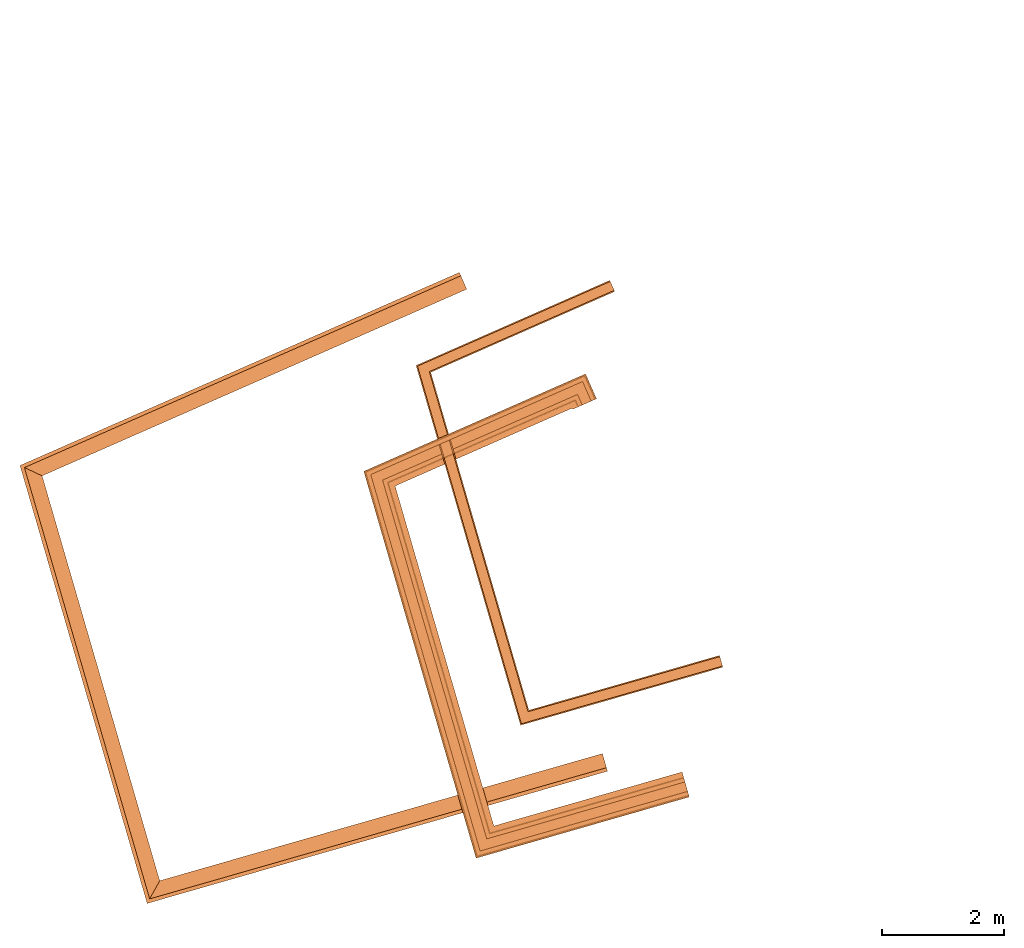
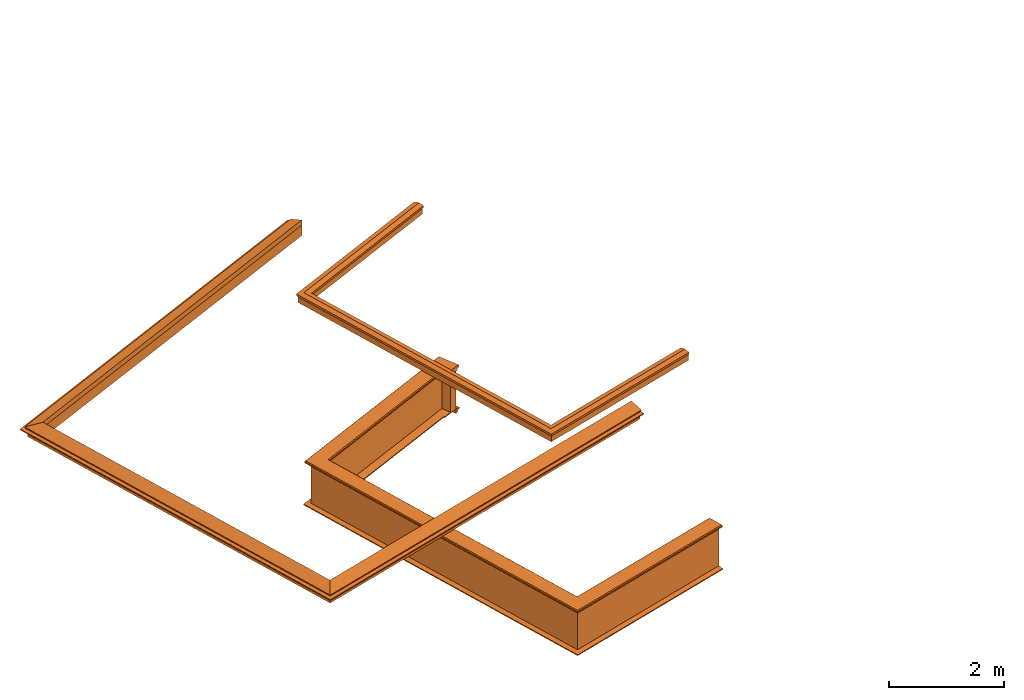
# One storey, part 9 of 10: 7 proxies.
"""IFC2X3 building model written with IfcOpenShell, lengths in metres."""

from ifc_helpers import new_model, entity, si_unit, frame, origin, place, context, subcontext, project, spatial, element, save


model = new_model("IFC2X3")

# Units and contexts
model_context = context("Model", 3, world=origin())
body_context = subcontext(model_context, "Body", "Model", "MODEL_VIEW")
ifc_project = project(units=[si_unit("PLANEANGLEUNIT", "RADIAN"), si_unit("MASSUNIT", "GRAM", prefix="KILO"), si_unit("FORCEUNIT", "NEWTON", prefix="KILO"), si_unit("LENGTHUNIT", "METRE")], contexts=[model_context])

# Site, building, storey
site_placement = place(None, origin())
site = spatial("IfcSite", under=ifc_project, at=site_placement, CompositionType="ELEMENT")
building_placement = place(None, origin())
building = spatial("IfcBuilding", under=site, at=building_placement, Name="Building plot-15", CompositionType="ELEMENT")
storey_placement = place(None, frame((0.0, 0.0, 11.05)))
storey = spatial("IfcBuildingStorey", under=building, at=storey_placement, Name="Floor 2", CompositionType="ELEMENT", Elevation=11.05)

# Proxies
proxy_1_placement = place(storey_placement, frame((0.0, 0.0, 3.6)))
axis2_placement3_d_1 = entity("IfcAxis2Placement3D", entity("IfcCartesianPoint", [0.0, 0.0, 0.0]))
element("IfcBuildingElementProxy", 1, at=proxy_1_placement, inside=storey, Name="eaves", CompositionType="ELEMENT", context=body_context, shape_type="SweptSolid", held_by="IfcProductRepresentation", body=[
    entity("IfcSurfaceCurveSweptAreaSolid", entity("IfcArbitraryClosedProfileDef", "AREA", None, entity("IfcPolyline", [entity("IfcCartesianPoint", [-0.11, 0.25]), entity("IfcCartesianPoint", [-0.33, 0.25]), entity("IfcCartesianPoint", [-0.33, 0.265]), entity("IfcCartesianPoint", [-0.318, 0.268]), entity("IfcCartesianPoint", [-0.309, 0.274]), entity("IfcCartesianPoint", [-0.303, 0.283]), entity("IfcCartesianPoint", [-0.3, 0.295]), entity("IfcCartesianPoint", [-0.285, 0.295]), entity("IfcCartesianPoint", [-0.285, 0.455]), entity("IfcCartesianPoint", [-0.205, 0.455]), entity("IfcCartesianPoint", [-0.205, 0.47]), entity("IfcCartesianPoint", [-0.19, 0.47]), entity("IfcCartesianPoint", [-0.189, 0.483]), entity("IfcCartesianPoint", [-0.186, 0.494]), entity("IfcCartesianPoint", [-0.179, 0.506]), entity("IfcCartesianPoint", [-0.17, 0.514]), entity("IfcCartesianPoint", [-0.16, 0.52]), entity("IfcCartesianPoint", [-0.149, 0.529]), entity("IfcCartesianPoint", [-0.143, 0.539]), entity("IfcCartesianPoint", [-0.14, 0.55]), entity("IfcCartesianPoint", [-0.12, 0.55]), entity("IfcCartesianPoint", [-0.11, 0.48]), entity("IfcCartesianPoint", [-0.11, 0.25])])), axis2_placement3_d_1, entity("IfcPolyline", [entity("IfcCartesianPoint", [95.6401338845165, 60.4839017679412]), entity("IfcCartesianPoint", [88.9047978560661, 57.5241106564342]), entity("IfcCartesianPoint", [90.6946933325155, 51.3603787835311]), entity("IfcCartesianPoint", [97.6861775273745, 53.3684815283957])]), 0.0, 1.0, entity("IfcPlane", axis2_placement3_d_1)),
])
proxy_2_placement = place(storey_placement, frame((0.0, 0.0, 3.6)))
axis2_placement3_d_2 = entity("IfcAxis2Placement3D", entity("IfcCartesianPoint", [0.0, 0.0, 0.0]))
element("IfcBuildingElementProxy", 2, at=proxy_2_placement, inside=storey, Name="eaves", CompositionType="ELEMENT", context=body_context, shape_type="SweptSolid", held_by="IfcProductRepresentation", body=[
    entity("IfcSurfaceCurveSweptAreaSolid", entity("IfcArbitraryClosedProfileDef", "AREA", None, entity("IfcPolyline", [entity("IfcCartesianPoint", [-0.11, 0.25]), entity("IfcCartesianPoint", [-0.11, 0.48]), entity("IfcCartesianPoint", [-0.08, 0.49]), entity("IfcCartesianPoint", [0.0, 0.25]), entity("IfcCartesianPoint", [-0.11, 0.25])])), axis2_placement3_d_2, entity("IfcPolyline", [entity("IfcCartesianPoint", [95.6401338845165, 60.4839017679412]), entity("IfcCartesianPoint", [88.9047978560661, 57.5241106564342]), entity("IfcCartesianPoint", [90.6946933325155, 51.3603787835311]), entity("IfcCartesianPoint", [97.6861775273745, 53.3684815283957])]), 0.0, 1.0, entity("IfcPlane", axis2_placement3_d_2)),
])
proxy_3_placement = place(storey_placement, origin())
axis2_placement3_d_3 = entity("IfcAxis2Placement3D", entity("IfcCartesianPoint", [0.0, 0.0, 0.0]))
element("IfcBuildingElementProxy", 3, at=proxy_3_placement, inside=storey, Name="parapet", CompositionType="ELEMENT", context=body_context, shape_type="SweptSolid", held_by="IfcProductRepresentation", body=[
    entity("IfcSurfaceCurveSweptAreaSolid", entity("IfcArbitraryClosedProfileDef", "AREA", None, entity("IfcPolyline", [entity("IfcCartesianPoint", [0.0, 0.25]), entity("IfcCartesianPoint", [0.795, 0.25]), entity("IfcCartesianPoint", [0.795, 0.09]), entity("IfcCartesianPoint", [0.02, 0.09]), entity("IfcCartesianPoint", [0.02, -0.08]), entity("IfcCartesianPoint", [0.0, -0.08]), entity("IfcCartesianPoint", [0.0, 0.25])])), axis2_placement3_d_3, entity("IfcPolyline", [entity("IfcCartesianPoint", [88.6612229492632, 57.3078440044142]), entity("IfcCartesianPoint", [88.6209918734423, 57.3993943213896]), entity("IfcCartesianPoint", [85.5910169005182, 56.067895350133]), entity("IfcCartesianPoint", [87.2457079823706, 50.3697569419318]), entity("IfcCartesianPoint", [90.3967398020299, 51.2748002016829])]), 0.0, 1.0, entity("IfcPlane", axis2_placement3_d_3)),
])
proxy_4_placement = place(storey_placement, origin())
axis2_placement3_d_4 = entity("IfcAxis2Placement3D", entity("IfcCartesianPoint", [0.0, 0.0, 0.0]))
element("IfcBuildingElementProxy", 4, at=proxy_4_placement, inside=storey, Name="parapet", CompositionType="ELEMENT", context=body_context, shape_type="SweptSolid", held_by="IfcProductRepresentation", body=[
    entity("IfcSurfaceCurveSweptAreaSolid", entity("IfcArbitraryClosedProfileDef", "AREA", None, entity("IfcPolyline", [entity("IfcCartesianPoint", [0.795, 0.265]), entity("IfcCartesianPoint", [0.807, 0.268]), entity("IfcCartesianPoint", [0.816, 0.274]), entity("IfcCartesianPoint", [0.822, 0.283]), entity("IfcCartesianPoint", [0.825, 0.295]), entity("IfcCartesianPoint", [0.84, 0.295]), entity("IfcCartesianPoint", [0.84, 0.305]), entity("IfcCartesianPoint", [0.842, 0.317]), entity("IfcCartesianPoint", [0.849, 0.326]), entity("IfcCartesianPoint", [0.858, 0.333]), entity("IfcCartesianPoint", [0.87, 0.335]), entity("IfcCartesianPoint", [0.882, 0.333]), entity("IfcCartesianPoint", [0.891, 0.326]), entity("IfcCartesianPoint", [0.898, 0.317]), entity("IfcCartesianPoint", [0.9, 0.305]), entity("IfcCartesianPoint", [0.9, 0.035]), entity("IfcCartesianPoint", [0.898, 0.023]), entity("IfcCartesianPoint", [0.891, 0.014]), entity("IfcCartesianPoint", [0.882, 0.007]), entity("IfcCartesianPoint", [0.87, 0.005]), entity("IfcCartesianPoint", [0.858, 0.007]), entity("IfcCartesianPoint", [0.849, 0.014]), entity("IfcCartesianPoint", [0.842, 0.023]), entity("IfcCartesianPoint", [0.84, 0.035]), entity("IfcCartesianPoint", [0.84, 0.045]), entity("IfcCartesianPoint", [0.825, 0.045]), entity("IfcCartesianPoint", [0.822, 0.057]), entity("IfcCartesianPoint", [0.816, 0.066]), entity("IfcCartesianPoint", [0.807, 0.072]), entity("IfcCartesianPoint", [0.795, 0.075]), entity("IfcCartesianPoint", [0.795, 0.265])])), axis2_placement3_d_4, entity("IfcPolyline", [entity("IfcCartesianPoint", [88.6612229492632, 57.3078440044142]), entity("IfcCartesianPoint", [88.6209918734423, 57.3993943213896]), entity("IfcCartesianPoint", [85.5910169005182, 56.067895350133]), entity("IfcCartesianPoint", [87.2457079823706, 50.3697569419318]), entity("IfcCartesianPoint", [90.3967398020299, 51.2748002016829])]), 0.0, 1.0, entity("IfcPlane", axis2_placement3_d_4)),
])
proxy_5_placement = place(storey_placement, origin())
axis2_placement3_d_5 = entity("IfcAxis2Placement3D", entity("IfcCartesianPoint", [0.0, 0.0, 0.0]))
element("IfcBuildingElementProxy", 5, at=proxy_5_placement, inside=storey, Name="parapet", CompositionType="ELEMENT", context=body_context, shape_type="SweptSolid", held_by="IfcProductRepresentation", body=[
    entity("IfcSurfaceCurveSweptAreaSolid", entity("IfcArbitraryClosedProfileDef", "AREA", None, entity("IfcPolyline", [entity("IfcCartesianPoint", [-0.1, 0.25]), entity("IfcCartesianPoint", [-0.1, 0.265]), entity("IfcCartesianPoint", [-0.085, 0.265]), entity("IfcCartesianPoint", [-0.084, 0.278]), entity("IfcCartesianPoint", [-0.081, 0.289]), entity("IfcCartesianPoint", [-0.074, 0.301]), entity("IfcCartesianPoint", [-0.065, 0.309]), entity("IfcCartesianPoint", [-0.055, 0.315]), entity("IfcCartesianPoint", [-0.044, 0.324]), entity("IfcCartesianPoint", [-0.038, 0.334]), entity("IfcCartesianPoint", [-0.035, 0.345]), entity("IfcCartesianPoint", [-0.015, 0.345]), entity("IfcCartesianPoint", [0.0, 0.25]), entity("IfcCartesianPoint", [-0.1, 0.25])])), axis2_placement3_d_5, entity("IfcPolyline", [entity("IfcCartesianPoint", [88.6612229492632, 57.3078440044142]), entity("IfcCartesianPoint", [88.6209918734423, 57.3993943213896]), entity("IfcCartesianPoint", [85.5910169005182, 56.067895350133]), entity("IfcCartesianPoint", [87.2457079823706, 50.3697569419318]), entity("IfcCartesianPoint", [90.3967398020299, 51.2748002016829])]), 0.0, 1.0, entity("IfcPlane", axis2_placement3_d_5)),
])
proxy_6_placement = place(storey_placement, frame((0.0, 0.0, 3.6)))
axis2_placement3_d_6 = entity("IfcAxis2Placement3D", entity("IfcCartesianPoint", [0.0, 0.0, 0.0]))
element("IfcBuildingElementProxy", 6, at=proxy_6_placement, inside=storey, Name="pergola beam", CompositionType="ELEMENT", context=body_context, shape_type="SweptSolid", held_by="IfcProductRepresentation", body=[
    entity("IfcSurfaceCurveSweptAreaSolid", entity("IfcArbitraryClosedProfileDef", "AREA", None, entity("IfcPolyline", [entity("IfcCartesianPoint", [-0.7, -0.08]), entity("IfcCartesianPoint", [-0.7, 0.08]), entity("IfcCartesianPoint", [-0.56, 0.08]), entity("IfcCartesianPoint", [-0.56, -0.08]), entity("IfcCartesianPoint", [-0.7, -0.08])])), axis2_placement3_d_6, entity("IfcPolyline", [entity("IfcCartesianPoint", [88.6759220636276, 57.4235329668821]), entity("IfcCartesianPoint", [85.5910169005182, 56.067895350133]), entity("IfcCartesianPoint", [87.2457079823706, 50.3697569419318]), entity("IfcCartesianPoint", [90.4544082272852, 51.2913637981696])]), 0.0, 1.0, entity("IfcPlane", axis2_placement3_d_6)),
])
proxy_7_placement = place(storey_placement, frame((0.0, 0.0, 3.6)))
axis2_placement3_d_7 = entity("IfcAxis2Placement3D", entity("IfcCartesianPoint", [0.0, 0.0, 0.0]))
element("IfcBuildingElementProxy", 7, at=proxy_7_placement, inside=storey, Name="pergola beam", CompositionType="ELEMENT", context=body_context, shape_type="SweptSolid", held_by="IfcProductRepresentation", body=[
    entity("IfcSurfaceCurveSweptAreaSolid", entity("IfcArbitraryClosedProfileDef", "AREA", None, entity("IfcPolyline", [entity("IfcCartesianPoint", [-0.5, 0.0]), entity("IfcCartesianPoint", [-0.52, -0.1]), entity("IfcCartesianPoint", [-0.56, -0.1]), entity("IfcCartesianPoint", [-0.56, 0.1]), entity("IfcCartesianPoint", [-0.52, 0.1]), entity("IfcCartesianPoint", [-0.5, 0.0])])), axis2_placement3_d_7, entity("IfcPolyline", [entity("IfcCartesianPoint", [88.6759220636276, 57.4235329668821]), entity("IfcCartesianPoint", [85.5910169005182, 56.067895350133]), entity("IfcCartesianPoint", [87.2457079823706, 50.3697569419318]), entity("IfcCartesianPoint", [90.4544082272852, 51.2913637981696])]), 0.0, 1.0, entity("IfcPlane", axis2_placement3_d_7)),
])

save(model, "model.ifc")
